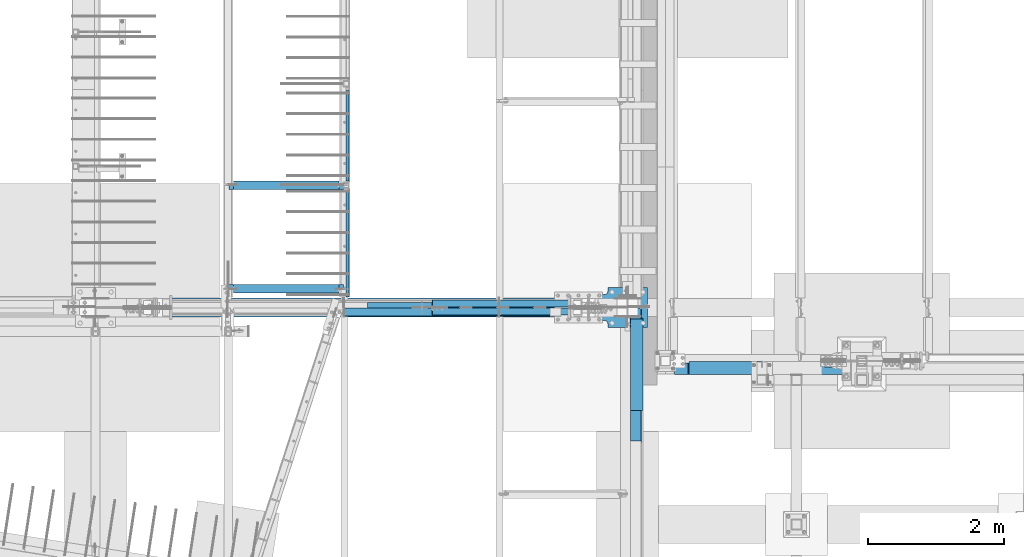
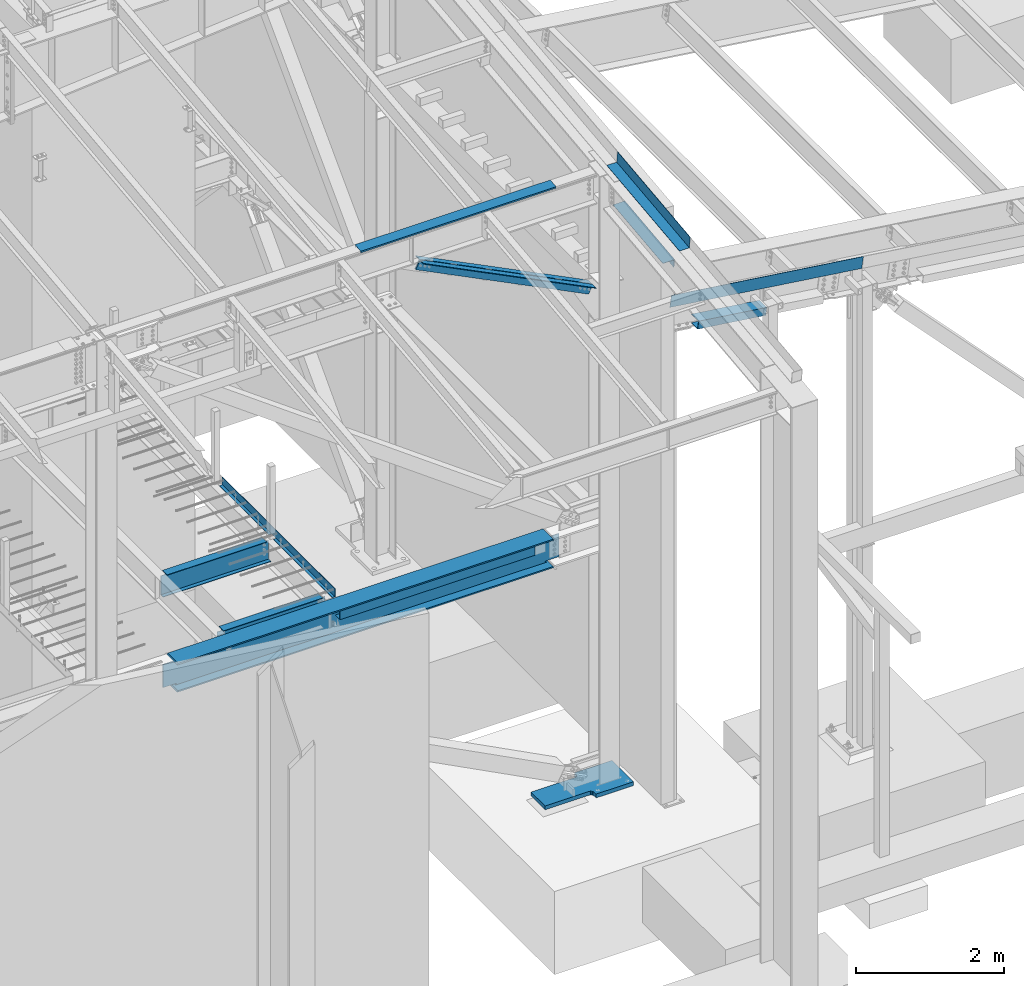
# One storey, part 716 of 1179: 11 beams, 2 members, 9 elements without a shape of their own.
"""IFC2X3 building model written with IfcOpenShell, lengths in millimetres."""

from ifc_helpers import new_model, si_unit, frame, origin_with_axes, place, context, subcontext, project, spatial, faceted_brep, material, type_object, element, aggregate, save


model = new_model("IFC2X3")

# Units and contexts
model_context = context("Model", 3, precision=1e-05, world=origin_with_axes())
body_context = subcontext(model_context, "Body", "Model", "MODEL_VIEW")
ifc_project = project(units=[si_unit("LENGTHUNIT", "METRE", prefix="MILLI"), si_unit("AREAUNIT", "SQUARE_METRE"), si_unit("VOLUMEUNIT", "CUBIC_METRE"), si_unit("MASSUNIT", "GRAM", prefix="KILO"), si_unit("TIMEUNIT", "SECOND"), si_unit("PLANEANGLEUNIT", "RADIAN"), si_unit("SOLIDANGLEUNIT", "STERADIAN"), si_unit("THERMODYNAMICTEMPERATUREUNIT", "DEGREE_CELSIUS"), si_unit("LUMINOUSINTENSITYUNIT", "LUMEN")], contexts=[model_context])

# Site, building, storey
site_placement = place(None, origin_with_axes())
site = spatial("IfcSite", under=ifc_project, at=site_placement, CompositionType="ELEMENT")
building_placement = place(site_placement, origin_with_axes())
building = spatial("IfcBuilding", under=site, at=building_placement, Name="Undefined", CompositionType="ELEMENT")
storey_placement = place(building_placement, origin_with_axes())
storey = spatial("IfcBuildingStorey", under=building, at=storey_placement, Name="Undefined", CompositionType="ELEMENT", Elevation=0.0)

# Assembly, beam
assembly_1_placement = place(storey_placement, origin_with_axes())
assembly_1 = element("IfcElementAssembly", 1, at=assembly_1_placement, inside=storey, Name="BEAM", AssemblyPlace="NOTDEFINED", PredefinedType="RIGID_FRAME")
ifc_material_1 = material(Name="STEEL/A36")
beam_type_1 = type_object("IfcBeamType", PredefinedType="NOTDEFINED")
beam_1_placement = place(assembly_1_placement, frame((21991.6380023565, 5508.63433466315, 9826.9162842795), z_axis=(-1.0, 0.0, 0.0), x_axis=(0.0, 0.0, 1.0)))
beam_1 = element("IfcBeam", 2, at=beam_1_placement, type_object=beam_type_1, material=ifc_material_1, Name="BENT_PLATE", context=body_context, shape_type="Brep", body=[
    faceted_brep([(-2.91038304567337e-11, -4.76250000000073, -1524.0), (-2.91038304567337e-11, -4.76250000000073, 1524.0), (2.91038304567337e-11, 4.76250000000073, 1524.0), (2.91038304567337e-11, 4.76250000000073, -1524.0), (42.9704233942375, 4.76249999974698, 1524.0), (42.9704233942375, 4.76249999974698, -1524.0), (32.3091293704474, -4.7625000001899, -1524.0), (32.3091293704474, -4.7625000001899, 1524.0), (25.4000000272608, -150.812499999743, 1524.0), (25.4000000272608, -150.812499999743, -1524.0), (16.8901864157524, -141.287499999744, -1524.0), (16.8901864157524, -141.287499999744, 1524.0), (8.54161044117063e-08, -150.812499999749, 1524.0), (8.54161044117063e-08, -150.812499999749, -1524.0), (8.54161044117063e-08, -141.287499999748, 1524.0), (8.54161044117063e-08, -141.287499999748, -1524.0)], [[[0, 1, 2, 3]], [[3, 2, 4, 5]], [[1, 0, 6, 7]], [[5, 4, 8, 9]], [[7, 6, 10, 11]], [[9, 8, 12, 13]], [[8, 4, 2, 1, 7, 11, 14, 12]], [[11, 10, 15, 14]], [[10, 6, 0, 3, 5, 9, 13, 15]], [[14, 15, 13, 12]]]),
])
aggregate(assembly_1, [beam_1])

assembly_2_placement = place(storey_placement, origin_with_axes())
assembly_2 = element("IfcElementAssembly", 3, at=assembly_2_placement, inside=storey, Name="BEAM", AssemblyPlace="NOTDEFINED", PredefinedType="RIGID_FRAME")
beam_type_2 = type_object("IfcBeamType", PredefinedType="NOTDEFINED")
beam_2_placement = place(assembly_2_placement, frame((20202.525, 7114.38125, 4235.45000610352), z_axis=(0.0, 1.0, 0.0), x_axis=(0.0, 0.0, -1.0)))
beam_2 = element("IfcBeam", 4, at=beam_2_placement, type_object=beam_type_2, material=ifc_material_1, Name="BENT_PLATE", context=body_context, shape_type="Brep", body=[
    faceted_brep([(133.350006103517, 47.6249992370613, 61.9124999999976), (127.000006103516, 47.6249992370613, 61.9124999999976), (127.000006103516, 3.17499999999927, 61.9124999999976), (133.350006103517, 3.17499999999927, 61.9124999999976), (133.350006103517, 3.17499999999927, 188.912499999998), (127.000006103516, 3.17499999999927, 188.912499999998), (127.000006103516, 47.6249992370613, 188.912499999998), (133.350006103517, 47.6249992370613, 188.912499999998), (0.0, 3.17499999999927, 61.9125000000004), (0.0, 3.17499999999927, -1524.0), (0.0, -3.17499999999927, -1524.0), (6.00266503170133e-10, -3.17499999922438, 1524.00000000052), (6.00266503170133e-10, 3.17500000077416, 1524.00000000052), (0.0, 3.17499999999927, 188.912499999998), (133.350006103517, -3.17499999999927, -1524.0), (127.000006103516, 3.17499999999927, -1524.0), (127.000006103516, 47.6249992370613, -1524.0), (133.350006103517, 47.6249992370613, -1524.0), (133.350006103517, -3.17499999999927, 1524.0), (127.000006103516, 3.17499999999927, 1524.0), (133.350006103517, 47.6249992370613, 1524.0), (127.000006103516, 47.6249992370613, 1524.0)], [[[0, 1, 2, 3]], [[4, 5, 6, 7]], [[3, 2, 5, 4]], [[8, 9, 10, 11, 12, 13]], [[14, 10, 9, 15, 16, 17]], [[11, 10, 14, 18]], [[19, 12, 11, 18, 20, 21]], [[21, 20, 7, 6]], [[19, 21, 6, 5]], [[9, 8, 13, 12, 19, 5, 2, 15]], [[16, 15, 2, 1]], [[17, 16, 1, 0]], [[20, 18, 14, 17, 0, 3, 4, 7]]]),
])
aggregate(assembly_2, [beam_2])

assembly_3_placement = place(storey_placement, origin_with_axes())
assembly_3 = element("IfcElementAssembly", 5, at=assembly_3_placement, inside=storey, Name="BEAM", AssemblyPlace="NOTDEFINED", PredefinedType="RIGID_FRAME")
ifc_material_2 = material(Name="STEEL/A992")
beam_type_3 = type_object("IfcBeamType", Name="W14X22", PredefinedType="NOTDEFINED")
beam_3_placement = place(assembly_3_placement, frame((18415.0, 5715.0, 3927.475), z_axis=(0.0, 0.0, 1.0), x_axis=(1.0, 0.0, 0.0)))
beam_3 = element("IfcBeam", 6, at=beam_3_placement, type_object=beam_type_3, material=ifc_material_2, Name="BEAM", ObjectType="W14X22", context=body_context, shape_type="Brep", body=[
    faceted_brep([(69.8500001907341, -3.17500000000291, 142.874999999998), (69.8500001907341, 3.17497569180705, 142.874999999998), (15.8750000000018, 3.17500000000291, 142.874999999998), (15.8750000000018, -3.17500000000291, 142.874999999998), (74.7100797087805, -3.17500000000291, 143.841729922586), (74.7100797087805, 3.17497496696888, 143.841729922586), (78.8302561769342, -3.17500000000291, 146.594743823063), (78.8302561769342, 3.17497290281608, 146.594743823063), (81.5832700774117, -3.17500000000291, 150.714920291217), (81.5832700774117, 3.17496981359, 150.714920291217), (82.5499999999993, -3.17500000000291, 155.574999809263), (82.5499999999993, 3.17496616959397, 155.574999809263), (82.5499999999993, -63.5, 174.625), (82.5499999999993, 63.5, 174.625), (82.5499999999993, 63.5, 166.6875), (82.5499999999993, 3.17500000000291, 166.6875), (82.5499999999993, -3.17500000000291, 166.6875), (82.5499999999993, -63.5, 166.6875), (1571.625, -63.5, -174.625), (1571.625, -63.5, -166.6875), (142.874999999996, -63.5, -166.6875), (142.874999999996, -63.5, -174.625), (1698.625, -3.17500000000018, -166.6875), (1571.625, -3.17500000000018, -166.6875), (1571.625, -3.17549991607666, -174.625), (1698.625, -3.17549991607666, -174.625), (142.874999999996, -3.17500000000018, -166.6875), (15.8750000000018, -3.17500000000291, -166.6875), (15.875, -3.17549991607666, -174.625), (142.874999999996, -3.17549991607666, -174.625), (15.875, 63.5, -174.625), (1698.625, 63.5, -174.625), (15.875, 63.5, -166.6875), (1698.625, 63.5, -166.6875), (15.8750000000018, 3.17500000000291, -166.6875), (1698.625, 3.17500000000018, -166.6875), (1698.625, 3.17500000000018, 142.875), (1698.625, -3.17500000000018, 142.875), (1644.64999980927, 3.17500000000018, 142.875), (1644.64999980927, -3.17500000000018, 142.875), (1639.78992029122, 3.17500000000018, 143.841729922588), (1639.78992029122, -3.17500000000018, 143.841729922588), (1635.66974382307, 3.17500000000018, 146.594743823066), (1635.66974382307, -3.17500000000018, 146.594743823066), (1632.91672992259, 3.17500000000018, 150.71492029122), (1632.91672992259, -3.17500000000018, 150.71492029122), (1631.95, 3.17500000000018, 155.574999809265), (1631.95, -3.17500000000018, 155.574999809265), (1631.95, -63.5, 174.625), (1631.95, -63.5, 166.6875), (1631.95, -3.17500000000018, 166.6875), (1631.95, 3.17500000000018, 166.6875), (1631.95, 63.5, 166.6875), (1631.95, 63.5, 174.625)], [[[0, 1, 2, 3]], [[4, 5, 1, 0]], [[6, 7, 5, 4]], [[8, 9, 7, 6]], [[10, 11, 9, 8]], [[12, 13, 14, 15, 11, 10, 16, 17]], [[18, 19, 20, 21]], [[22, 23, 24, 25]], [[19, 18, 24, 23]], [[19, 23, 26, 20]], [[27, 28, 29, 26]], [[20, 26, 29, 21]], [[28, 30, 31, 25, 24, 18, 21, 29]], [[30, 32, 33, 31]], [[32, 34, 35, 33]], [[22, 25, 31, 33, 35, 36, 37]], [[37, 36, 38, 39]], [[39, 38, 40, 41]], [[41, 40, 42, 43]], [[43, 42, 44, 45]], [[45, 44, 46, 47]], [[48, 49, 50, 47, 46, 51, 52, 53]], [[49, 48, 12, 17]], [[50, 49, 17, 16]], [[8, 6, 4, 0, 3, 27, 26, 23, 22, 37, 39, 41, 43, 45, 47, 50, 16, 10]], [[34, 32, 30, 28, 27, 3, 2]], [[51, 46, 44, 42, 40, 38, 36, 35, 34, 2, 1, 5, 7, 9, 11, 15]], [[52, 51, 15, 14]], [[53, 52, 14, 13]], [[48, 53, 13, 12]]]),
])
aggregate(assembly_3, [beam_3])

assembly_4_placement = place(storey_placement, origin_with_axes())
assembly_4 = element("IfcElementAssembly", 7, at=assembly_4_placement, inside=storey, Name="BEAM", AssemblyPlace="NOTDEFINED", PredefinedType="RIGID_FRAME")
beam_4_placement = place(assembly_4_placement, frame((18415.0, 7239.0, 3927.475), z_axis=(0.0, 0.0, 1.0), x_axis=(1.0, 0.0, 0.0)))
beam_4 = element("IfcBeam", 8, at=beam_4_placement, type_object=beam_type_3, material=ifc_material_2, Name="BEAM", ObjectType="W14X22", context=body_context, shape_type="Brep", body=[
    faceted_brep([(69.8500001907341, -3.17500000000291, 142.874999999998), (69.8500001907341, 3.17497569180705, 142.874999999998), (15.8750000000018, 3.17500000000291, 142.874999999998), (15.8750000000018, -3.17500000000291, 142.874999999998), (74.7100797087805, -3.17500000000291, 143.841729922586), (74.7100797087805, 3.17497496696888, 143.841729922586), (78.8302561769342, -3.17500000000291, 146.594743823063), (78.8302561769342, 3.17497290281608, 146.594743823063), (81.5832700774117, -3.17500000000291, 150.714920291217), (81.5832700774117, 3.17496981359, 150.714920291217), (82.5499999999993, -3.17500000000291, 155.574999809263), (82.5499999999993, 3.17496616959397, 155.574999809263), (82.5499999999993, -63.5, 174.625), (82.5499999999993, 63.5, 174.625), (82.5499999999993, 63.5, 166.6875), (82.5499999999993, 3.17500000000291, 166.6875), (82.5499999999993, -3.17500000000291, 166.6875), (82.5499999999993, -63.5, 166.6875), (1571.625, 3.17500000000018, -166.6875), (1571.625, 63.5, -166.6875), (142.875000000002, 63.5, -166.6875), (142.875000000002, 3.17549991607666, -166.6875), (15.8750000000018, -3.17500000000291, -166.6875), (15.8750000000018, -63.5, -166.6875), (1698.625, -63.5, -166.6875), (1698.625, -3.17500000000018, -166.6875), (15.8750000000018, -63.5, -174.625), (1698.625, -63.5, -174.625), (1571.625, 63.5, -174.625), (1571.625, 3.17549991607666, -174.625), (1698.625, 3.17549991607666, -174.625), (15.8750000000018, 3.17549991607666, -174.625), (142.875000000002, 3.17549991607666, -174.625), (142.875000000002, 63.5, -174.625), (15.8750000000018, 3.17500000000291, -166.6875), (1698.625, 3.17500000000018, -166.6875), (1698.625, 3.17500000000018, 142.875), (1698.625, -3.17500000000018, 142.875), (1644.64999980927, 3.17500000000018, 142.875), (1644.64999980927, -3.17500000000018, 142.875), (1639.78992029122, 3.17500000000018, 143.841729922588), (1639.78992029122, -3.17500000000018, 143.841729922588), (1635.66974382307, 3.17500000000018, 146.594743823066), (1635.66974382307, -3.17500000000018, 146.594743823066), (1632.91672992259, 3.17500000000018, 150.71492029122), (1632.91672992259, -3.17500000000018, 150.71492029122), (1631.95, 3.17500000000018, 155.574999809265), (1631.95, -3.17500000000018, 155.574999809265), (1631.95, -63.5, 174.625), (1631.95, -63.5, 166.6875), (1631.95, -3.17500000000018, 166.6875), (1631.95, 3.17500000000018, 166.6875), (1631.95, 63.5, 166.6875), (1631.95, 63.5, 174.625)], [[[0, 1, 2, 3]], [[4, 5, 1, 0]], [[6, 7, 5, 4]], [[8, 9, 7, 6]], [[10, 11, 9, 8]], [[12, 13, 14, 15, 11, 10, 16, 17]], [[18, 19, 20, 21]], [[22, 23, 24, 25]], [[23, 26, 27, 24]], [[28, 29, 30, 27, 26, 31, 32, 33]], [[21, 32, 31, 34]], [[20, 33, 32, 21]], [[19, 28, 33, 20]], [[18, 29, 28, 19]], [[35, 30, 29, 18]], [[25, 24, 27, 30, 35, 36, 37]], [[37, 36, 38, 39]], [[39, 38, 40, 41]], [[41, 40, 42, 43]], [[43, 42, 44, 45]], [[45, 44, 46, 47]], [[48, 49, 50, 47, 46, 51, 52, 53]], [[49, 48, 12, 17]], [[50, 49, 17, 16]], [[8, 6, 4, 0, 3, 22, 25, 37, 39, 41, 43, 45, 47, 50, 16, 10]], [[34, 31, 26, 23, 22, 3, 2]], [[51, 46, 44, 42, 40, 38, 36, 35, 18, 21, 34, 2, 1, 5, 7, 9, 11, 15]], [[52, 51, 15, 14]], [[53, 52, 14, 13]], [[48, 53, 13, 12]]]),
])
aggregate(assembly_4, [beam_4])

assembly_5_placement = place(storey_placement, origin_with_axes())
assembly_5 = element("IfcElementAssembly", 9, at=assembly_5_placement, inside=storey, Name="BEAM", AssemblyPlace="NOTDEFINED", PredefinedType="RIGID_FRAME")
beam_type_4 = type_object("IfcBeamType", PredefinedType="NOTDEFINED")
beam_5_placement = place(assembly_5_placement, frame((24350.6630000739, 4449.27737892002, 9752.83965333129), z_axis=(0.0, -0.993676357192036, -0.112282221021698), x_axis=(1.0, 0.0, 0.0)))
beam_5 = element("IfcBeam", 10, at=beam_5_placement, type_object=beam_type_4, material=ifc_material_1, Name="BENT_PLATE", context=body_context, shape_type="Brep", body=[
    faceted_brep([(1.46610545925796e-09, -3.17499999991014, -989.012500000246), (0.0, -3.17499999999927, 989.0125), (0.0, 3.17499999999927, 989.0125), (1.46610545925796e-09, 3.17500000008476, -989.012500000244), (153.986999993529, 3.17499999991014, 989.012500000471), (153.986999998917, 3.17500000008476, -989.012500000017), (160.336999998919, -3.17499999991014, -989.012500000009), (160.336999993531, -3.1750000000884, 989.01250000048), (153.986999994762, 187.324999994393, 989.01250000074), (153.986999997687, 187.324999997045, -989.012499999749), (160.336999994761, 187.324999994395, 989.012500000749), (160.336999997686, 187.324999997043, -989.01249999974)], [[[0, 1, 2, 3]], [[3, 2, 4, 5]], [[1, 0, 6, 7]], [[5, 4, 8, 9]], [[4, 2, 1, 7, 10, 8]], [[7, 6, 11, 10]], [[6, 0, 3, 5, 9, 11]], [[10, 11, 9, 8]]]),
])

# Assembly, beams
assembly_6_placement = place(storey_placement, origin_with_axes())
assembly_6 = element("IfcElementAssembly", 11, at=assembly_6_placement, inside=storey, Name="BEAM", AssemblyPlace="NOTDEFINED", PredefinedType="RIGID_FRAME")
beam_type_5 = type_object("IfcBeamType", PredefinedType="NOTDEFINED")
beam_6_placement = place(assembly_6_placement, frame((26288.2014571588, 4448.17500000176, 7961.45609310439), z_axis=(0.99100656965293, 0.0, -0.133813223953134), x_axis=(-0.133813222971046, 0.0, -0.991006569785539)))
beam_6 = element("IfcBeam", 12, at=beam_6_placement, type_object=beam_type_5, material=ifc_material_1, Name="BENT_PLATE", context=body_context, shape_type="Brep", body=[
    faceted_brep([(190.499999994603, 3.17500000002565, -1274.27727015632), (184.149999994364, 3.17500000000018, -1274.2772701563), (184.14999999505, 166.687500006369, -1274.27727015592), (190.499999995051, 166.687500006369, -1274.27727015592), (190.499999994099, 3.17500000002565, -1511.30000000064), (184.149999994068, 3.17500000000018, -1511.30000000063), (-1.11322151497006e-09, 3.17500000000018, -1511.30000000033), (-1.11322151497006e-09, -3.17500000000018, -1511.30000000033), (1.11140252556652e-09, -3.17500000000018, 1511.30000000033), (1.11140252556652e-09, 3.17500000000018, 1511.30000000033), (-9.40417521633208e-10, 3.17500000000018, -1274.27727015592), (190.49999999407, -3.17500000000018, -1511.30000000064), (190.499999997875, -3.17500000000018, 1511.30000000002), (184.149999997875, 3.17500000000018, 1511.30000000003), (190.49999999707, 166.687500007794, 1511.29999999993), (184.149999997067, 166.687500007794, 1511.29999999994), (190.499999996908, 166.687500007681, 1289.00038672857), (184.149999996907, 166.687500007681, 1289.00038672857), (190.499999997253, 111.125000843772, 1289.00038671062), (184.149999997251, 111.125000843772, 1289.00038671063), (190.499999996926, 111.125000660666, 959.956338028045), (184.149999996924, 111.125000660666, 959.956338028056), (190.499999996671, 166.687500007512, 959.956338027499), (184.149999996669, 166.687500007512, 959.956338027499)], [[[0, 1, 2, 3]], [[4, 5, 1, 0]], [[6, 7, 8, 9, 10]], [[8, 7, 11, 12]], [[13, 9, 8, 12, 14, 15]], [[15, 14, 16, 17]], [[18, 19, 17, 16]], [[20, 21, 19, 18]], [[22, 23, 21, 20]], [[23, 22, 3, 2]], [[13, 15, 17, 19, 21, 23, 2, 1]], [[6, 10, 9, 13, 1, 5]], [[11, 7, 6, 5, 4]], [[22, 20, 18, 16, 14, 12, 11, 4, 0, 3]]]),
])
beam_type_6 = type_object("IfcBeamType", PredefinedType="NOTDEFINED")
beam_7_placement = place(assembly_6_placement, frame((25747.0581181782, 4642.64374999937, 7515.50762140242), z_axis=(-0.99100656978554, 0.0, 0.133813222971043), x_axis=(0.0, -1.0, 0.0)))
beam_7 = element("IfcBeam", 13, at=beam_7_placement, type_object=beam_type_6, material=ifc_material_1, Name="BENT_PLATE", context=body_context, shape_type="Brep", body=[
    faceted_brep([(4.91127138957381e-11, -3.17500000014843, -536.575000000117), (-8.09450284577906e-11, -3.17499999985193, 536.575000000117), (-4.91127138957381e-11, 3.17500000015025, 536.575000000106), (8.09450284577906e-11, 3.17499999985375, -536.575000000124), (197.643750000509, 3.17499999916981, 536.575000000132), (197.643750001124, 3.17499999887332, -536.575000000103), (191.293750001125, -3.17500000109612, -536.575000000095), (191.293750000509, -3.17500000079963, 536.575000000139), (197.643750000756, -123.82500000358, 536.575000000339), (197.643750000878, -123.825000004683, -536.574999999899), (191.293750000877, -117.475000004681, -536.574999999906), (191.293750000756, -117.475000003578, 536.575000000328), (27.7812499988258, -123.825000003739, 536.575000000368), (27.7812499986276, -123.825000004523, -536.574999999866), (27.7812499988258, -117.475000003737, 536.575000000357), (27.7812499986276, -117.475000004521, -536.574999999873)], [[[0, 1, 2, 3]], [[3, 2, 4, 5]], [[1, 0, 6, 7]], [[5, 4, 8, 9]], [[7, 6, 10, 11]], [[9, 8, 12, 13]], [[8, 4, 2, 1, 7, 11, 14, 12]], [[11, 10, 15, 14]], [[10, 6, 0, 3, 5, 9, 13, 15]], [[14, 15, 13, 12]]]),
])
aggregate(assembly_6, [beam_6, beam_7])

# Assembly, members
assembly_7_placement = place(storey_placement, origin_with_axes())
assembly_7 = element("IfcElementAssembly", 14, at=assembly_7_placement, inside=storey, Name="ANGLE", AssemblyPlace="NOTDEFINED", PredefinedType="RIGID_FRAME")
member_type = type_object("IfcMemberType", Name="L6X4X3/8", PredefinedType="NOTDEFINED")
member_1_placement = place(assembly_7_placement, frame((24273.7234021117, 5378.45, 7827.63176201769), z_axis=(-0.447199447044005, 0.0, -0.894434265088014), x_axis=(-0.894434265088011, 0.0, 0.447199447044012)))
member_1 = element("IfcMember", 15, at=member_1_placement, type_object=member_type, material=ifc_material_2, Name="ANGLE", ObjectType="L6X4X3/8", context=body_context, shape_type="Brep", body=[
    faceted_brep([(200.559736484847, 50.8000000000002, -76.200000000179), (200.55973648472, 50.8000000000002, 76.1999999998843), (3217.81173859551, 50.8000000000002, 76.199999997687), (3217.81173859563, 50.8000000000002, -76.2000000023763), (200.55973648472, 41.2749999999996, 76.1999999998843), (3217.81173859551, 41.2749999999996, 76.199999997687), (200.55973648484, 41.2749999999996, -66.6750000001739), (3217.81173859563, 41.2749999999996, -66.6750000023712), (200.55973648484, -50.8000000000002, -66.6750000001739), (3217.81173859563, -50.8000000000002, -66.6750000023712), (200.559736484847, -50.8000000000002, -76.200000000179), (3217.81173859563, -50.8000000000002, -76.2000000023763)], [[[0, 1, 2, 3]], [[1, 4, 5, 2]], [[4, 6, 7, 5]], [[6, 8, 9, 7]], [[8, 10, 11, 9]], [[10, 0, 3, 11]], [[5, 7, 9, 11, 3, 2]], [[10, 8, 6, 4, 1, 0]]]),
])
member_2_placement = place(assembly_7_placement, frame((21261.7122767711, 5492.75, 9333.57777002665), z_axis=(-0.447199447044005, 0.0, -0.894434265088014), x_axis=(0.894434265088014, 0.0, -0.447199447044005)))
member_2 = element("IfcMember", 16, at=member_2_placement, type_object=member_type, material=ifc_material_2, Name="ANGLE", ObjectType="L6X4X3/8", context=body_context, shape_type="Brep", body=[
    faceted_brep([(149.692440786856, 50.8000000000002, -76.1999999999243), (149.692440786977, 50.8000000000002, 76.2000000001353), (3166.94444289777, 50.8000000000002, 76.2000000023327), (3166.94444289764, 50.8000000000002, -76.199999997727), (149.692440786977, 41.2749999999996, 76.2000000001353), (3166.94444289777, 41.2749999999996, 76.2000000023327), (149.692440786865, 41.2749999999996, -66.6749999999229), (3166.94444289765, 41.2749999999996, -66.6749999977255), (149.692440786865, -50.8000000000002, -66.6749999999229), (3166.94444289765, -50.8000000000002, -66.6749999977255), (149.692440786856, -50.8000000000002, -76.1999999999243), (3166.94444289764, -50.8000000000002, -76.199999997727)], [[[0, 1, 2, 3]], [[1, 4, 5, 2]], [[4, 6, 7, 5]], [[6, 8, 9, 7]], [[8, 10, 11, 9]], [[10, 0, 3, 11]], [[5, 7, 9, 11, 3, 2]], [[10, 8, 6, 4, 1, 0]]]),
])
aggregate(assembly_7, [member_1, member_2])

# Beam
beam_type_7 = type_object("IfcBeamType", PredefinedType="NOTDEFINED")
beam_8_placement = place(assembly_5_placement, frame((24350.6629999527, 4591.65719274678, 9240.12866069458), z_axis=(0.0, -0.993676146336441, -0.112284087038017), x_axis=(1.0, 0.0, 0.0)))
beam_8 = element("IfcBeam", 17, at=beam_8_placement, type_object=beam_type_7, material=ifc_material_1, Name="BENT_PLATE", context=body_context, shape_type="Brep", body=[
    faceted_brep([(7.6397554948926e-11, -3.17500000033942, -677.862500000236), (-3.27418092638254e-11, -3.17499999965185, 677.86250000023), (-7.6397554948926e-11, 3.17500000034306, 677.862500000233), (3.27418092638254e-11, 3.1749999996573, -677.862500000231), (185.737000044835, 3.17500000165091, 677.862500000248), (185.737000045097, 3.17500000096334, -677.862500000218), (179.387000045099, -3.17499999907886, -677.862500000221), (179.387000044837, -3.1749999983931, 677.862500000244), (185.73700004489, -136.524999944981, 677.862500000193), (185.737000045043, -136.524999945821, -677.862500000272), (179.387000044891, -136.524999944981, 677.862500000193), (179.387000045044, -136.524999945821, -677.862500000273)], [[[0, 1, 2, 3]], [[3, 2, 4, 5]], [[1, 0, 6, 7]], [[5, 4, 8, 9]], [[4, 2, 1, 7, 10, 8]], [[7, 6, 11, 10]], [[6, 0, 3, 5, 9, 11]], [[10, 11, 9, 8]]]),
])

aggregate(assembly_5, [beam_8, beam_5])

# Assembly, beams
assembly_8_placement = place(storey_placement, origin_with_axes())
assembly_8 = element("IfcElementAssembly", 18, at=assembly_8_placement, inside=storey, Name="BEAM", AssemblyPlace="NOTDEFINED", PredefinedType="RIGID_FRAME")
beam_type_8 = type_object("IfcBeamType", PredefinedType="NOTDEFINED")
beam_9_placement = place(assembly_8_placement, frame((21636.1511803629, 5428.45624193841, 3930.65000614851), z_axis=(-1.0, 0.0, 0.0), x_axis=(0.0, -1.0, 0.0)))
beam_9 = element("IfcBeam", 19, at=beam_9_placement, type_object=beam_type_8, material=ifc_material_1, Name="BENT_PLATE", context=body_context, shape_type="Brep", body=[
    faceted_brep([(0.0, -3.17499999999927, -1524.0), (6.00266503170133e-10, -3.17499999922438, 1524.00000000052), (6.00266503170133e-10, 3.17500000077416, 1524.00000000052), (0.0, 3.17499999999927, -1524.0), (115.093749393807, 3.1750000427628, 1523.99999999973), (115.093749389823, 3.1750000427628, -1524.00000000027), (121.443749713683, -3.17499995487788, -1524.00000000029), (121.443749717668, -3.17499995487788, 1523.99999999971), (115.093741943772, 149.224999951026, 1523.99999999961), (115.093741942226, 149.224999948687, -1524.00000000039), (121.443741943773, 149.225000274888, 1523.9999999996), (121.443741942227, 149.225000272549, -1524.0000000004)], [[[0, 1, 2, 3]], [[3, 2, 4, 5]], [[1, 0, 6, 7]], [[5, 4, 8, 9]], [[4, 2, 1, 7, 10, 8]], [[7, 6, 11, 10]], [[6, 0, 3, 5, 9, 11]], [[10, 11, 9, 8]]]),
])
beam_type_9 = type_object("IfcBeamType", Name="W18X97", PredefinedType="NOTDEFINED")
beam_10_placement = place(assembly_8_placement, frame((16459.2, 5435.6, 3865.5625), z_axis=(0.0, 0.0, 1.0), x_axis=(1.0, 0.0, 0.0)))
beam_10 = element("IfcBeam", 20, at=beam_10_placement, type_object=beam_type_9, material=ifc_material_2, Name="BEAM", ObjectType="W18X97", context=body_context, shape_type="Brep", body=[
    faceted_brep([(6991.85047968295, -141.2875, 214.3125), (6991.85047968295, -7.14375000000018, 214.3125), (6992.07968730892, -7.14375000000018, 213.9155), (6992.07968730892, 7.14375000000018, 213.9155), (6991.85047968295, 7.14375000000018, 214.3125), (6991.85047968295, 141.2875, 214.3125), (6979.01889407309, 141.2875, 236.5375), (6979.01889407309, -141.2875, 236.5375), (1121.59170892856, -141.2875, -214.3125), (1108.76051168335, -141.2875, -236.5375), (6991.85007744375, -141.2875, -236.5375), (6979.01888019855, -141.2875, -214.3125), (1108.76051168335, 141.2875, -236.5375), (6991.85007744375, 141.2875, -236.5375), (1121.59170892856, 141.2875, -214.3125), (6979.01888019855, 141.2875, -214.3125), (1121.59170892856, 7.14375000000018, -214.3125), (6979.01888019855, 7.14375000000018, -214.3125), (6931.23611462415, -7.14375000000018, 207.055856973128), (6931.23611462415, 7.14375000000018, 207.055856973128), (6945.81247882115, 7.14375000000018, 213.9155), (6945.81247882115, -7.14375000000018, 213.9155), (6927.3803660151, -7.14375000000018, 203.741552423033), (6927.3803660151, 7.14375000000018, 203.741552423033), (6925.77893954035, -7.14375000000018, 198.915907882361), (6925.77893954035, 7.14375000000018, 198.915907882361), (6926.88814662109, -7.14375000000018, 193.953945403766), (6926.88814662109, 7.14375000000018, 193.953945403766), (6930.39192912577, -7.14375000000018, 190.269529554973), (6930.39192912577, 7.14375000000018, 190.269529554973), (6935.2919171639, -7.14375000000018, 188.9125), (6935.2919171639, 7.14375000000018, 188.9125), (7141.07547882115, -7.14375000000018, 188.9125), (7141.07547882115, 7.14375000000018, 188.9125), (7141.07547882115, -7.14375000000018, -188.9125), (7141.07547882115, 7.14375000000018, -188.9125), (6936.2899171639, -7.14375000000018, -188.9125), (6936.2899171639, 7.14375000000018, -188.9125), (6931.38992912577, -7.14375000000018, -190.269529554975), (6931.38992912577, 7.14375000000018, -190.269529554975), (6927.88614662108, -7.14375000000018, -193.953945403767), (6927.88614662108, 7.14375000000018, -193.953945403767), (6926.77693954035, -7.14375000000018, -198.915907882363), (6926.77693954035, 7.14375000000018, -198.915907882363), (6928.3783660151, -7.14375000000018, -203.741552423034), (6928.3783660151, 7.14375000000018, -203.741552423034), (6932.23411462415, -7.14375000000018, -207.055856973128), (6932.23411462415, 7.14375000000018, -207.055856973128), (6946.81047882115, -7.14375000000018, -213.9155), (6946.81047882115, 7.14375000000018, -213.9155), (6978.78967950985, -7.14375000000018, -213.9155), (6978.78967950985, 7.14375000000018, -213.9155), (6979.01888019855, -7.14375000000018, -214.3125), (1121.59170892856, -7.14375000000018, -214.3125), (1121.82090961725, -7.14375000000018, -213.9155), (1121.82090961725, 7.14375000000018, -213.9155), (1153.80011030595, -7.14375000000018, -213.9155), (1153.80011030595, 7.14375000000018, -213.9155), (1168.37647450296, -7.14375000000018, -207.055856973128), (1168.37647450296, 7.14375000000018, -207.055856973128), (1172.23222311201, -7.14375000000018, -203.741552423034), (1172.23222311201, 7.14375000000018, -203.741552423034), (1173.83364958676, -7.14375000000018, -198.915907882363), (1173.83364958676, 7.14375000000018, -198.915907882363), (1172.72444250602, -7.14375000000018, -193.953945403767), (1172.72444250602, 7.14375000000018, -193.953945403767), (1169.22066000134, -7.14375000000018, -190.269529554975), (1169.22066000134, 7.14375000000018, -190.269529554975), (1164.32067196321, -7.14375000000018, -188.9125), (1164.32067196321, 7.14375000000018, -188.9125), (959.535110305955, -7.14375000000018, -188.9125), (959.535110305955, 7.14375000000018, -188.9125), (959.535110305955, -7.14375000000018, 188.9125), (959.535110305955, 7.14375000000018, 188.9125), (1165.31867196321, -7.14375000000018, 188.912499999999), (1165.31867196321, 7.14375000000018, 188.912499999999), (1170.21866000134, -7.14375000000018, 190.269529554974), (1170.21866000134, 7.14375000000018, 190.269529554974), (1173.72244250602, -7.14375000000018, 193.953945403766), (1173.72244250602, 7.14375000000018, 193.953945403766), (1174.83164958675, -7.14375000000018, 198.915907882361), (1174.83164958675, 7.14375000000018, 198.915907882361), (1173.230223112, -7.14375000000018, 203.741552423032), (1173.230223112, 7.14375000000018, 203.741552423032), (1169.37447450296, -7.14375000000018, 207.055856973127), (1169.37447450296, 7.14375000000018, 207.055856973127), (1154.79811030595, -7.14375000000018, 213.9155), (1154.79811030595, 7.14375000000018, 213.9155), (1108.53090181818, -7.14375000000018, 213.9155), (1108.53090181818, 7.14375000000018, 213.9155), (1121.59169505402, -141.2875, 236.5375), (1121.59169505402, 141.2875, 236.5375), (1108.76010944415, 141.2875, 214.3125), (1108.76010944415, 7.14375000000018, 214.3125), (1108.76010944415, -7.14375000000018, 214.3125), (1108.76010944415, -141.2875, 214.3125)], [[[0, 1, 2, 3, 4, 5, 6, 7]], [[8, 9, 10, 11]], [[9, 12, 13, 10]], [[12, 14, 15, 13]], [[14, 16, 17, 15]], [[18, 19, 20, 21]], [[22, 23, 19, 18]], [[24, 25, 23, 22]], [[26, 27, 25, 24]], [[28, 29, 27, 26]], [[30, 31, 29, 28]], [[31, 30, 32, 33]], [[32, 34, 35, 33]], [[36, 37, 35, 34]], [[38, 39, 37, 36]], [[40, 41, 39, 38]], [[42, 43, 41, 40]], [[44, 45, 43, 42]], [[46, 47, 45, 44]], [[48, 49, 47, 46]], [[49, 48, 50, 51]], [[10, 13, 15, 17, 51, 50, 52, 11]], [[53, 8, 11, 52]], [[54, 55, 16, 14, 12, 9, 8, 53]], [[56, 57, 55, 54]], [[58, 59, 57, 56]], [[60, 61, 59, 58]], [[62, 63, 61, 60]], [[64, 65, 63, 62]], [[66, 67, 65, 64]], [[68, 69, 67, 66]], [[69, 68, 70, 71]], [[72, 73, 71, 70]], [[74, 75, 73, 72]], [[76, 77, 75, 74]], [[78, 79, 77, 76]], [[80, 81, 79, 78]], [[82, 83, 81, 80]], [[84, 85, 83, 82]], [[86, 87, 85, 84]], [[87, 86, 88, 89]], [[90, 91, 92, 93, 89, 88, 94, 95]], [[90, 95, 0, 7]], [[91, 90, 7, 6]], [[92, 91, 6, 5]], [[93, 92, 5, 4]], [[20, 19, 23, 25, 27, 29, 31, 33, 35, 37, 39, 41, 43, 45, 47, 49, 51, 17, 16, 55, 57, 59, 61, 63, 65, 67, 69, 71, 73, 75, 77, 79, 81, 83, 85, 87, 89, 93, 4, 3]], [[21, 20, 3, 2]], [[94, 88, 86, 84, 82, 80, 78, 76, 74, 72, 70, 68, 66, 64, 62, 60, 58, 56, 54, 53, 52, 50, 48, 46, 44, 42, 40, 38, 36, 34, 32, 30, 28, 26, 24, 22, 18, 21, 2, 1]], [[95, 94, 1, 0]]]),
])
aggregate(assembly_8, [beam_9, beam_10])

# Assembly, beam
assembly_9_placement = place(storey_placement, origin_with_axes())
assembly_9 = element("IfcElementAssembly", 21, at=assembly_9_placement, inside=storey, Name="COLUMN", AssemblyPlace="NOTDEFINED", PredefinedType="RIGID_FRAME")
ifc_material_3 = material(Name="STEEL/A572-GR.50")
beam_type_10 = type_object("IfcBeamType", PredefinedType="NOTDEFINED")
beam_11_placement = place(assembly_9_placement, frame((24599.89949646, 5435.6, -247.649999999999), z_axis=(0.0, -1.0, 0.0), x_axis=(-1.0, 0.0, 0.0)))
beam_11 = element("IfcBeam", 22, at=beam_11_placement, type_object=beam_type_10, material=ifc_material_3, context=body_context, shape_type="Brep", body=[
    faceted_brep([(584.199496459958, -31.75, 292.1), (584.199496459958, -31.75, 241.30000076336), (584.199496459958, 31.75, 241.30000076336), (584.199496459958, 31.75, 292.1), (588.066416150308, -31.75, 221.859682691178), (588.066416150308, 31.75, 221.859682691178), (599.078471752222, -31.75, 205.378976818563), (599.078471752222, 31.75, 205.378976818563), (615.559177624837, -31.75, 194.366921216651), (615.559177624837, 31.75, 194.366921216651), (634.999495697019, -31.75, 190.500001526299), (634.999495697019, 31.75, 190.500001526299), (1320.79949645996, -31.75, 190.500001526299), (1320.79949645996, 31.75, 190.500001526299), (0.0, -31.75, -292.1), (0.0, -31.75, 292.1), (0.0, 31.75, 292.1), (0.0, 31.75, -292.1), (584.199496459958, 31.75, -292.1), (584.199496459958, -31.75, -292.1), (584.199496459958, 31.75, -241.30000076336), (584.199496459958, -31.75, -241.30000076336), (588.066416150308, 31.75, -221.859682691178), (588.066416150308, -31.75, -221.859682691178), (599.078471752222, 31.75, -205.378976818563), (599.078471752222, -31.75, -205.378976818563), (615.559177624837, 31.75, -194.366921216651), (615.559177624837, -31.75, -194.366921216651), (634.999495697019, 31.75, -190.500001526299), (634.999495697019, -31.75, -190.500001526299), (1320.79949645996, -31.75, -190.500001526299), (1320.79949645996, 31.75, -190.500001526299)], [[[0, 1, 2, 3]], [[4, 5, 2, 1]], [[6, 7, 5, 4]], [[8, 9, 7, 6]], [[10, 11, 9, 8]], [[12, 13, 11, 10]], [[14, 15, 16, 17]], [[14, 17, 18, 19]], [[19, 18, 20, 21]], [[21, 20, 22, 23]], [[23, 22, 24, 25]], [[25, 24, 26, 27]], [[27, 26, 28, 29]], [[30, 29, 28, 31]], [[8, 6, 4, 1, 0, 15, 14, 19, 21, 23, 25, 27, 29, 30, 12, 10]], [[16, 15, 0, 3]], [[31, 28, 26, 24, 22, 20, 18, 17, 16, 3, 2, 5, 7, 9, 11, 13]], [[30, 31, 13, 12]]]),
])
aggregate(assembly_9, [beam_11])

save(model, "model.ifc")
